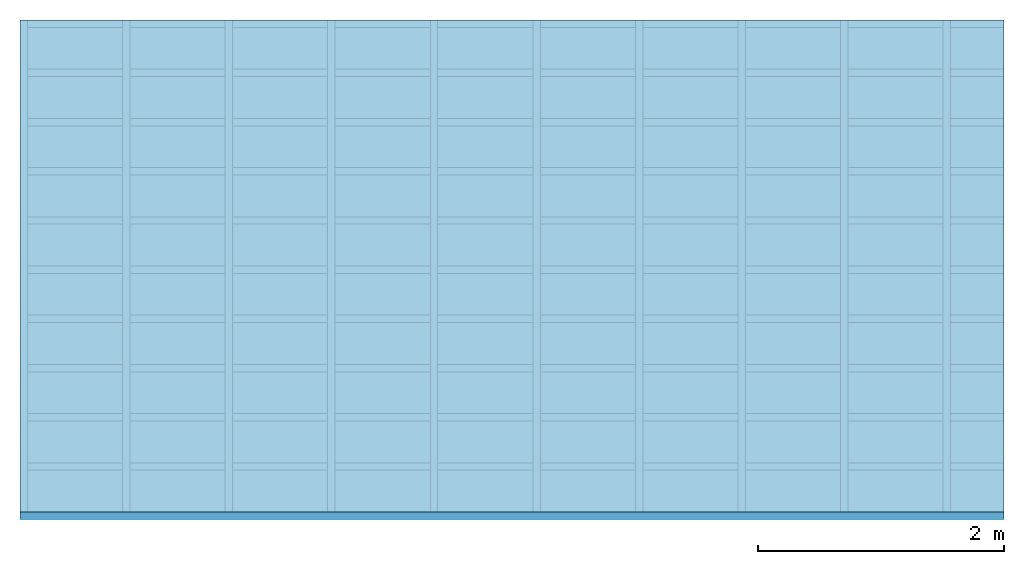
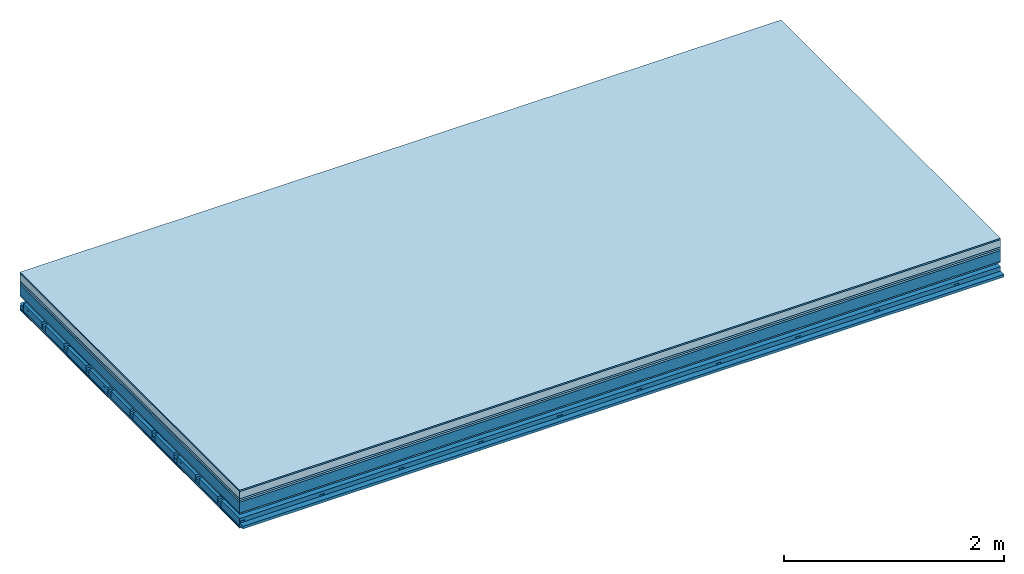
# One storey: 8 plates, 4 members, 1 element without a shape of its own.
"""IFC4 building model written with IfcOpenShell, lengths in metres."""

from ifc_helpers import new_model, si_unit, derived_unit, direction, frame, frame_2d, origin, origin_with_axes, place, context, project, spatial, polyline, rectangle, outline, extrude, material, layer, layer_set, type_object, element, aggregate, save


model = new_model("IFC4")

# Units and contexts
plan_context = context("Plan", 3, precision=1e-05, world=origin(), true_north=direction((0.0, 1.0)))
model_context = context("Model", 3, precision=1e-05, world=origin(), true_north=direction((0.0, 1.0)))
ifc_project = project(units=[si_unit("LENGTHUNIT", "METRE"), derived_unit("SOUNDPRESSUREUNIT", [(si_unit("PRESSUREUNIT", "PASCAL", prefix="MICRO"), 0)]), si_unit("ENERGYUNIT", "JOULE", prefix="MEGA"), si_unit("MASSUNIT", "GRAM", prefix="KILO"), derived_unit("THERMALTRANSMITTANCEUNIT", [(si_unit("POWERUNIT", "WATT"), 1), (si_unit("AREAUNIT", "SQUARE_METRE"), -1), (si_unit("THERMODYNAMICTEMPERATUREUNIT", "KELVIN"), -1)]), derived_unit("AREADENSITYUNIT", [(si_unit("MASSUNIT", "GRAM", prefix="KILO"), 1), (si_unit("AREAUNIT", "SQUARE_METRE"), -1)]), derived_unit("USERDEFINED", [(si_unit("ENERGYUNIT", "JOULE", prefix="MEGA"), 1), (si_unit("AREAUNIT", "SQUARE_METRE"), -1)])], contexts=[plan_context, model_context])

# Site, building, storey
site = spatial("IfcSite", under=ifc_project)
building_placement = place(None, origin())
building = spatial("IfcBuilding", under=site, at=building_placement)
storey_placement = place(building_placement, origin())
storey = spatial("IfcBuildingStorey", under=building, at=storey_placement)

# Slab, members, plates
ifc_material_1 = material(Category="11.013")
ifc_layer_1 = layer(ifc_material_1, 0.015, Name="Flooring")
ifc_material_2 = material(Name="Cement screed", Category="04.006")
ifc_layer_2 = layer(ifc_material_2, 0.08, Name="On-material")
ifc_material_3 = material(Name="Wood fiber generic product", Category="10.009")
ifc_layer_3 = layer(ifc_material_3, 0.02, Name="Impact sound insulation")
ifc_material_4 = material(Category="10.004")
ifc_layer_4 = layer(ifc_material_4, 0.02, Name="Additional insulation")
ifc_material_5 = material(Name="no composite action")
ifc_layer_5 = layer(ifc_material_5, 0.0, Name="Bond")
ifc_layer_6 = layer(None, 0.12, Name="Supporting structure")
ifc_material_6 = material(Name="of the art")
ifc_layer_7 = layer(ifc_material_6, 0.0, Name="Bond")
ifc_material_7 = material(Category="03.007")
ifc_layer_8 = layer(ifc_material_7, 0.015, Name="Lower layer 1")
ifc_layer_9 = layer(None, 0.095, Name="Coupling")
ifc_layer_10 = layer(None, 0.03, Name="Battens / profiles")
ifc_material_8 = material(Name="Plasterboard type A", Category="03.008")
ifc_layer_11 = layer(ifc_material_8, 0.0125, Name="Ceiling covering 1st layer")
ifc_layer_12 = layer(ifc_material_8, 0.0125, Name="Ceiling covering layer 2")
ifc_material_9 = material(Category="04.001")
ifc_layer_13 = layer(ifc_material_9, 0.003, Name="Surface / treatment")
ifc_layer_set = layer_set([ifc_layer_1, ifc_layer_2, ifc_layer_3, ifc_layer_4, ifc_layer_5, ifc_layer_6, ifc_layer_7, ifc_layer_8, ifc_layer_9, ifc_layer_10, ifc_layer_11, ifc_layer_12, ifc_layer_13])
slab_type = type_object("IfcSlabType", Name="A2159", PredefinedType="NOTDEFINED", material=ifc_layer_set)
slab_placement = place(None, frame((0.0, 0.0, 0.0), z_axis=(0.0, 0.0, -1.0), x_axis=(1.0, 0.0, 0.0)))
slab = element("IfcSlab", 1, at=slab_placement, inside=storey, type_object=slab_type, material=ifc_layer_set, Name="Slab #1")
ifc_material_10 = material(Name="Solid timber panel")
member_1_placement = place(slab_placement, origin())
member_1 = element("IfcMember", 2, at=member_1_placement, material=ifc_material_10, Name="Supporting structure", context=plan_context, shape_type="SweptSolid", body=[
    extrude(rectangle(XDim=1.0, YDim=0.12, at=frame_2d((0.5, 0.06), x_axis=(1.0, 0.0))), frame((0.0, 4.0, 0.135), z_axis=(0.0, -1.0, 0.0), x_axis=(1.0, 0.0, 0.0)), (0.0, 0.0, 1.0), 4.0),
    extrude(rectangle(XDim=1.0, YDim=0.12, at=frame_2d((0.5, 0.06), x_axis=(1.0, 0.0))), frame((1.0, 4.0, 0.135), z_axis=(0.0, -1.0, 0.0), x_axis=(1.0, 0.0, 0.0)), (0.0, 0.0, 1.0), 4.0),
    extrude(rectangle(XDim=1.0, YDim=0.12, at=frame_2d((0.5, 0.06), x_axis=(1.0, 0.0))), frame((2.0, 4.0, 0.135), z_axis=(0.0, -1.0, 0.0), x_axis=(1.0, 0.0, 0.0)), (0.0, 0.0, 1.0), 4.0),
    extrude(rectangle(XDim=1.0, YDim=0.12, at=frame_2d((0.5, 0.06), x_axis=(1.0, 0.0))), frame((3.0, 4.0, 0.135), z_axis=(0.0, -1.0, 0.0), x_axis=(1.0, 0.0, 0.0)), (0.0, 0.0, 1.0), 4.0),
    extrude(rectangle(XDim=1.0, YDim=0.12, at=frame_2d((0.5, 0.06), x_axis=(1.0, 0.0))), frame((4.0, 4.0, 0.135), z_axis=(0.0, -1.0, 0.0), x_axis=(1.0, 0.0, 0.0)), (0.0, 0.0, 1.0), 4.0),
    extrude(rectangle(XDim=1.0, YDim=0.12, at=frame_2d((0.5, 0.06), x_axis=(1.0, 0.0))), frame((5.0, 4.0, 0.135), z_axis=(0.0, -1.0, 0.0), x_axis=(1.0, 0.0, 0.0)), (0.0, 0.0, 1.0), 4.0),
    extrude(rectangle(XDim=1.0, YDim=0.12, at=frame_2d((0.5, 0.06), x_axis=(1.0, 0.0))), frame((6.0, 4.0, 0.135), z_axis=(0.0, -1.0, 0.0), x_axis=(1.0, 0.0, 0.0)), (0.0, 0.0, 1.0), 4.0),
    extrude(rectangle(XDim=1.0, YDim=0.12, at=frame_2d((0.5, 0.06), x_axis=(1.0, 0.0))), frame((7.0, 4.0, 0.135), z_axis=(0.0, -1.0, 0.0), x_axis=(1.0, 0.0, 0.0)), (0.0, 0.0, 1.0), 4.0),
])
ifc_material_11 = material()
member_2_placement = place(slab_placement, origin())
member_2 = element("IfcMember", 3, at=member_2_placement, material=ifc_material_11, Name="Coupling", context=plan_context, shape_type="SweptSolid", body=[
    extrude(outline(polyline([(0.0, 0.0), (0.06, 0.0), (0.04, 0.02), (0.02, 0.02), (0.0, 0.0)])), frame((0.0, 4.0, 0.345), z_axis=(0.0, -1.0, 0.0), x_axis=(1.0, 0.0, 0.0)), (0.0, 0.0, 1.0), 4.0),
    extrude(outline(polyline([(0.0, 0.0), (0.06, 0.0), (0.04, 0.02), (0.02, 0.02), (0.0, 0.0)])), frame((0.834, 4.0, 0.345), z_axis=(0.0, -1.0, 0.0), x_axis=(1.0, 0.0, 0.0)), (0.0, 0.0, 1.0), 4.0),
    extrude(outline(polyline([(0.0, 0.0), (0.06, 0.0), (0.04, 0.02), (0.02, 0.02), (0.0, 0.0)])), frame((1.668, 4.0, 0.345), z_axis=(0.0, -1.0, 0.0), x_axis=(1.0, 0.0, 0.0)), (0.0, 0.0, 1.0), 4.0),
    extrude(outline(polyline([(0.0, 0.0), (0.06, 0.0), (0.04, 0.02), (0.02, 0.02), (0.0, 0.0)])), frame((2.502, 4.0, 0.345), z_axis=(0.0, -1.0, 0.0), x_axis=(1.0, 0.0, 0.0)), (0.0, 0.0, 1.0), 4.0),
    extrude(outline(polyline([(0.0, 0.0), (0.06, 0.0), (0.04, 0.02), (0.02, 0.02), (0.0, 0.0)])), frame((3.336, 4.0, 0.345), z_axis=(0.0, -1.0, 0.0), x_axis=(1.0, 0.0, 0.0)), (0.0, 0.0, 1.0), 4.0),
    extrude(outline(polyline([(0.0, 0.0), (0.06, 0.0), (0.04, 0.02), (0.02, 0.02), (0.0, 0.0)])), frame((4.17, 4.0, 0.345), z_axis=(0.0, -1.0, 0.0), x_axis=(1.0, 0.0, 0.0)), (0.0, 0.0, 1.0), 4.0),
    extrude(outline(polyline([(0.0, 0.0), (0.06, 0.0), (0.04, 0.02), (0.02, 0.02), (0.0, 0.0)])), frame((5.004, 4.0, 0.345), z_axis=(0.0, -1.0, 0.0), x_axis=(1.0, 0.0, 0.0)), (0.0, 0.0, 1.0), 4.0),
    extrude(outline(polyline([(0.0, 0.0), (0.06, 0.0), (0.04, 0.02), (0.02, 0.02), (0.0, 0.0)])), frame((5.838, 4.0, 0.345), z_axis=(0.0, -1.0, 0.0), x_axis=(1.0, 0.0, 0.0)), (0.0, 0.0, 1.0), 4.0),
    extrude(outline(polyline([(0.0, 0.0), (0.06, 0.0), (0.04, 0.02), (0.02, 0.02), (0.0, 0.0)])), frame((6.672, 4.0, 0.345), z_axis=(0.0, -1.0, 0.0), x_axis=(1.0, 0.0, 0.0)), (0.0, 0.0, 1.0), 4.0),
    extrude(outline(polyline([(0.0, 0.0), (0.06, 0.0), (0.04, 0.02), (0.02, 0.02), (0.0, 0.0)])), frame((7.506, 4.0, 0.345), z_axis=(0.0, -1.0, 0.0), x_axis=(1.0, 0.0, 0.0)), (0.0, 0.0, 1.0), 4.0),
])
member_3_placement = place(slab_placement, origin())
member_3 = element("IfcMember", 4, at=member_3_placement, material=ifc_material_11, Name="Battens / profiles", context=plan_context, shape_type="SweptSolid", body=[
    extrude(rectangle(XDim=0.06, YDim=0.03, at=frame_2d((0.03, 0.015), x_axis=(1.0, 0.0))), frame((0.0, 0.0, 0.365), z_axis=(1.0, 0.0, 0.0), x_axis=(0.0, 1.0, 0.0)), (0.0, 0.0, 1.0), 8.0),
    extrude(rectangle(XDim=0.06, YDim=0.03, at=frame_2d((0.03, 0.015), x_axis=(1.0, 0.0))), frame((0.0, 0.4, 0.365), z_axis=(1.0, 0.0, 0.0), x_axis=(0.0, 1.0, 0.0)), (0.0, 0.0, 1.0), 8.0),
    extrude(rectangle(XDim=0.06, YDim=0.03, at=frame_2d((0.03, 0.015), x_axis=(1.0, 0.0))), frame((0.0, 0.8, 0.365), z_axis=(1.0, 0.0, 0.0), x_axis=(0.0, 1.0, 0.0)), (0.0, 0.0, 1.0), 8.0),
    extrude(rectangle(XDim=0.06, YDim=0.03, at=frame_2d((0.03, 0.015), x_axis=(1.0, 0.0))), frame((0.0, 1.2, 0.365), z_axis=(1.0, 0.0, 0.0), x_axis=(0.0, 1.0, 0.0)), (0.0, 0.0, 1.0), 8.0),
    extrude(rectangle(XDim=0.06, YDim=0.03, at=frame_2d((0.03, 0.015), x_axis=(1.0, 0.0))), frame((0.0, 1.6, 0.365), z_axis=(1.0, 0.0, 0.0), x_axis=(0.0, 1.0, 0.0)), (0.0, 0.0, 1.0), 8.0),
    extrude(rectangle(XDim=0.06, YDim=0.03, at=frame_2d((0.03, 0.015), x_axis=(1.0, 0.0))), frame((0.0, 2.0, 0.365), z_axis=(1.0, 0.0, 0.0), x_axis=(0.0, 1.0, 0.0)), (0.0, 0.0, 1.0), 8.0),
    extrude(rectangle(XDim=0.06, YDim=0.03, at=frame_2d((0.03, 0.015), x_axis=(1.0, 0.0))), frame((0.0, 2.4, 0.365), z_axis=(1.0, 0.0, 0.0), x_axis=(0.0, 1.0, 0.0)), (0.0, 0.0, 1.0), 8.0),
    extrude(rectangle(XDim=0.06, YDim=0.03, at=frame_2d((0.03, 0.015), x_axis=(1.0, 0.0))), frame((0.0, 2.8, 0.365), z_axis=(1.0, 0.0, 0.0), x_axis=(0.0, 1.0, 0.0)), (0.0, 0.0, 1.0), 8.0),
    extrude(rectangle(XDim=0.06, YDim=0.03, at=frame_2d((0.03, 0.015), x_axis=(1.0, 0.0))), frame((0.0, 3.2, 0.365), z_axis=(1.0, 0.0, 0.0), x_axis=(0.0, 1.0, 0.0)), (0.0, 0.0, 1.0), 8.0),
    extrude(rectangle(XDim=0.06, YDim=0.03, at=frame_2d((0.03, 0.015), x_axis=(1.0, 0.0))), frame((0.0, 3.6, 0.365), z_axis=(1.0, 0.0, 0.0), x_axis=(0.0, 1.0, 0.0)), (0.0, 0.0, 1.0), 8.0),
    extrude(rectangle(XDim=0.06, YDim=0.03, at=frame_2d((0.03, 0.015), x_axis=(1.0, 0.0))), frame((0.0, 4.0, 0.365), z_axis=(1.0, 0.0, 0.0), x_axis=(0.0, 1.0, 0.0)), (0.0, 0.0, 1.0), 8.0),
])
ifc_material_12 = material()
member_4_placement = place(slab_placement, origin())
member_4 = element("IfcMember", 5, at=member_4_placement, material=ifc_material_12, Name="Cavity", context=plan_context, shape_type="SweptSolid", body=[
    extrude(rectangle(XDim=0.34, YDim=0.08, at=frame_2d((0.17, 0.04), x_axis=(1.0, 0.0))), frame((0.0, 0.06, 0.315), z_axis=(1.0, 0.0, 0.0), x_axis=(0.0, 1.0, 0.0)), (0.0, 0.0, 1.0), 8.0),
    extrude(rectangle(XDim=0.34, YDim=0.08, at=frame_2d((0.17, 0.04), x_axis=(1.0, 0.0))), frame((0.0, 0.46, 0.315), z_axis=(1.0, 0.0, 0.0), x_axis=(0.0, 1.0, 0.0)), (0.0, 0.0, 1.0), 8.0),
    extrude(rectangle(XDim=0.34, YDim=0.08, at=frame_2d((0.17, 0.04), x_axis=(1.0, 0.0))), frame((0.0, 0.86, 0.315), z_axis=(1.0, 0.0, 0.0), x_axis=(0.0, 1.0, 0.0)), (0.0, 0.0, 1.0), 8.0),
    extrude(rectangle(XDim=0.34, YDim=0.08, at=frame_2d((0.17, 0.04), x_axis=(1.0, 0.0))), frame((0.0, 1.26, 0.315), z_axis=(1.0, 0.0, 0.0), x_axis=(0.0, 1.0, 0.0)), (0.0, 0.0, 1.0), 8.0),
    extrude(rectangle(XDim=0.34, YDim=0.08, at=frame_2d((0.17, 0.04), x_axis=(1.0, 0.0))), frame((0.0, 1.66, 0.315), z_axis=(1.0, 0.0, 0.0), x_axis=(0.0, 1.0, 0.0)), (0.0, 0.0, 1.0), 8.0),
    extrude(rectangle(XDim=0.34, YDim=0.08, at=frame_2d((0.17, 0.04), x_axis=(1.0, 0.0))), frame((0.0, 2.06, 0.315), z_axis=(1.0, 0.0, 0.0), x_axis=(0.0, 1.0, 0.0)), (0.0, 0.0, 1.0), 8.0),
    extrude(rectangle(XDim=0.34, YDim=0.08, at=frame_2d((0.17, 0.04), x_axis=(1.0, 0.0))), frame((0.0, 2.46, 0.315), z_axis=(1.0, 0.0, 0.0), x_axis=(0.0, 1.0, 0.0)), (0.0, 0.0, 1.0), 8.0),
    extrude(rectangle(XDim=0.34, YDim=0.08, at=frame_2d((0.17, 0.04), x_axis=(1.0, 0.0))), frame((0.0, 2.86, 0.315), z_axis=(1.0, 0.0, 0.0), x_axis=(0.0, 1.0, 0.0)), (0.0, 0.0, 1.0), 8.0),
    extrude(rectangle(XDim=0.34, YDim=0.08, at=frame_2d((0.17, 0.04), x_axis=(1.0, 0.0))), frame((0.0, 3.26, 0.315), z_axis=(1.0, 0.0, 0.0), x_axis=(0.0, 1.0, 0.0)), (0.0, 0.0, 1.0), 8.0),
    extrude(rectangle(XDim=0.34, YDim=0.08, at=frame_2d((0.17, 0.04), x_axis=(1.0, 0.0))), frame((0.0, 3.66, 0.315), z_axis=(1.0, 0.0, 0.0), x_axis=(0.0, 1.0, 0.0)), (0.0, 0.0, 1.0), 8.0),
])
plate_1_placement = place(slab_placement, origin())
plate_1 = element("IfcPlate", 6, at=plate_1_placement, material=ifc_material_1, Name="Flooring", context=plan_context, shape_type="SweptSolid", body=[
    extrude(rectangle(XDim=8.0, YDim=4.0, at=frame_2d((4.0, 2.0), x_axis=(1.0, 0.0))), origin_with_axes(), (0.0, 0.0, 1.0), 0.015),
])
plate_2_placement = place(slab_placement, origin())
plate_2 = element("IfcPlate", 7, at=plate_2_placement, material=ifc_material_2, Name="On-material", context=plan_context, shape_type="SweptSolid", body=[
    extrude(rectangle(XDim=8.0, YDim=4.0, at=frame_2d((4.0, 2.0), x_axis=(1.0, 0.0))), frame((0.0, 0.0, 0.015), z_axis=(0.0, 0.0, 1.0), x_axis=(1.0, 0.0, 0.0)), (0.0, 0.0, 1.0), 0.08),
])
plate_3_placement = place(slab_placement, origin())
plate_3 = element("IfcPlate", 8, at=plate_3_placement, material=ifc_material_3, Name="Impact sound insulation", context=plan_context, shape_type="SweptSolid", body=[
    extrude(rectangle(XDim=8.0, YDim=4.0, at=frame_2d((4.0, 2.0), x_axis=(1.0, 0.0))), frame((0.0, 0.0, 0.095), z_axis=(0.0, 0.0, 1.0), x_axis=(1.0, 0.0, 0.0)), (0.0, 0.0, 1.0), 0.02),
])
plate_4_placement = place(slab_placement, origin())
plate_4 = element("IfcPlate", 9, at=plate_4_placement, material=ifc_material_4, Name="Additional insulation", context=plan_context, shape_type="SweptSolid", body=[
    extrude(rectangle(XDim=8.0, YDim=4.0, at=frame_2d((4.0, 2.0), x_axis=(1.0, 0.0))), frame((0.0, 0.0, 0.115), z_axis=(0.0, 0.0, 1.0), x_axis=(1.0, 0.0, 0.0)), (0.0, 0.0, 1.0), 0.02),
])
plate_5_placement = place(slab_placement, origin())
plate_5 = element("IfcPlate", 10, at=plate_5_placement, material=ifc_material_7, Name="Lower layer 1", context=plan_context, shape_type="SweptSolid", body=[
    extrude(rectangle(XDim=8.0, YDim=4.0, at=frame_2d((4.0, 2.0), x_axis=(1.0, 0.0))), frame((0.0, 0.0, 0.255), z_axis=(0.0, 0.0, 1.0), x_axis=(1.0, 0.0, 0.0)), (0.0, 0.0, 1.0), 0.015),
])
plate_6_placement = place(slab_placement, origin())
plate_6 = element("IfcPlate", 11, at=plate_6_placement, material=ifc_material_8, Name="Ceiling covering 1st layer", context=plan_context, shape_type="SweptSolid", body=[
    extrude(rectangle(XDim=8.0, YDim=4.0, at=frame_2d((4.0, 2.0), x_axis=(1.0, 0.0))), frame((0.0, 0.0, 0.395), z_axis=(0.0, 0.0, 1.0), x_axis=(1.0, 0.0, 0.0)), (0.0, 0.0, 1.0), 0.0125),
])
plate_7_placement = place(slab_placement, origin())
plate_7 = element("IfcPlate", 12, at=plate_7_placement, material=ifc_material_8, Name="Ceiling covering layer 2", context=plan_context, shape_type="SweptSolid", body=[
    extrude(rectangle(XDim=8.0, YDim=4.0, at=frame_2d((4.0, 2.0), x_axis=(1.0, 0.0))), frame((0.0, 0.0, 0.4075), z_axis=(0.0, 0.0, 1.0), x_axis=(1.0, 0.0, 0.0)), (0.0, 0.0, 1.0), 0.0125),
])
plate_8_placement = place(slab_placement, origin())
plate_8 = element("IfcPlate", 13, at=plate_8_placement, material=ifc_material_9, Name="Surface / treatment", context=plan_context, shape_type="SweptSolid", body=[
    extrude(rectangle(XDim=8.0, YDim=4.0, at=frame_2d((4.0, 2.0), x_axis=(1.0, 0.0))), frame((0.0, 0.0, 0.42), z_axis=(0.0, 0.0, 1.0), x_axis=(1.0, 0.0, 0.0)), (0.0, 0.0, 1.0), 0.003),
])
aggregate(slab, [plate_1, plate_2, plate_3, plate_4, member_1, plate_5, member_2, member_3, member_4, plate_6, plate_7, plate_8])

save(model, "model.ifc")
